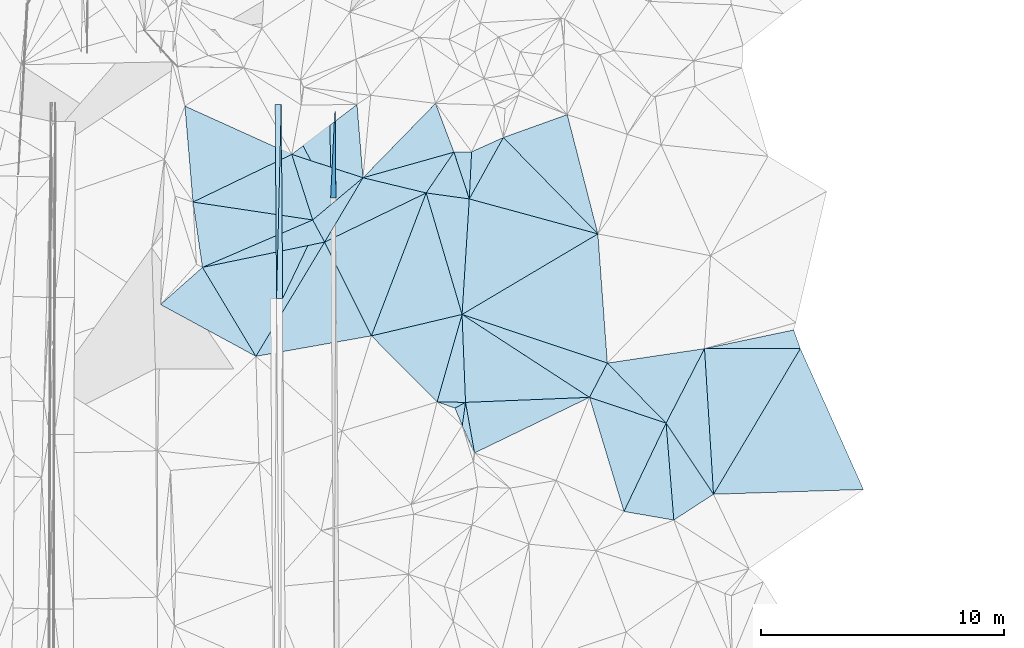
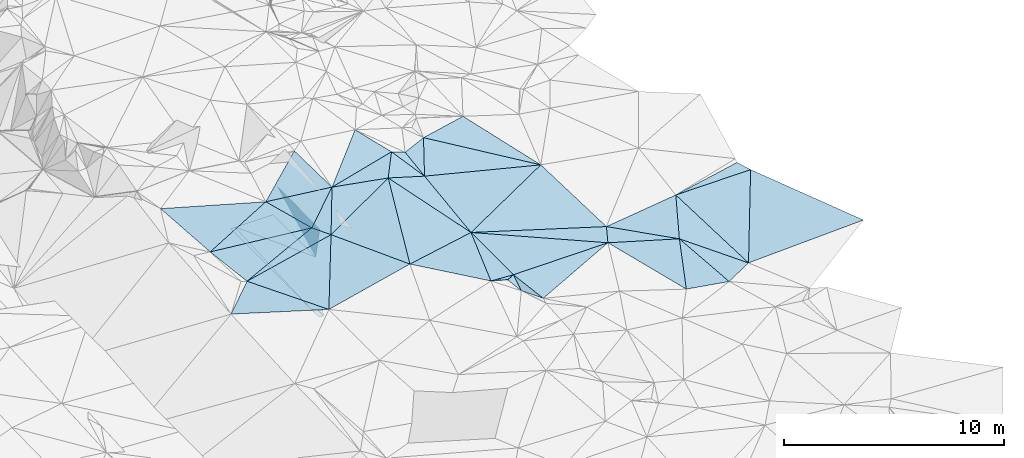
# One storey, part 154 of 275: 45 plates.
"""IFC2X3 building model written with IfcOpenShell, lengths in millimetres."""

from ifc_helpers import new_model, si_unit, frame, origin_with_axes, place, context, subcontext, project, spatial, polyline, outline, extrude, material, type_object, element, save


model = new_model("IFC2X3")

# Units and contexts
model_context = context("Model", 3, precision=1e-05, world=origin_with_axes())
body_context = subcontext(model_context, "Body", "Model", "MODEL_VIEW")
ifc_project = project(units=[si_unit("LENGTHUNIT", "METRE", prefix="MILLI"), si_unit("AREAUNIT", "SQUARE_METRE"), si_unit("VOLUMEUNIT", "CUBIC_METRE"), si_unit("MASSUNIT", "GRAM", prefix="KILO"), si_unit("TIMEUNIT", "SECOND"), si_unit("PLANEANGLEUNIT", "RADIAN"), si_unit("SOLIDANGLEUNIT", "STERADIAN"), si_unit("THERMODYNAMICTEMPERATUREUNIT", "DEGREE_CELSIUS"), si_unit("LUMINOUSINTENSITYUNIT", "LUMEN")], contexts=[model_context])

# Site, building, storey
site_placement = place(None, origin_with_axes())
site = spatial("IfcSite", under=ifc_project, at=site_placement, CompositionType="ELEMENT")
building_placement = place(site_placement, origin_with_axes())
building = spatial("IfcBuilding", under=site, at=building_placement, Name="Undefined", CompositionType="ELEMENT")
storey_placement = place(building_placement, origin_with_axes())
storey = spatial("IfcBuildingStorey", under=building, at=storey_placement, Name="Undefined", CompositionType="ELEMENT", Elevation=0.0)

# Plates
ifc_material = material()
plate_type_1 = type_object("IfcPlateType", PredefinedType="NOTDEFINED")
plate_1_placement = place(storey_placement, frame((-45854.497626776, 116819.736850131, 45079.1672889497), z_axis=(0.989904777680498, 0.00940713676587161, -0.141421486709737), x_axis=(0.00717878399998597, -0.999842046384469, -0.0162587620069682)))
element("IfcPlate", 1, at=plate_1_placement, inside=storey, type_object=plate_type_1, material=ifc_material, Name="00_PR", context=body_context, shape_type="SweptSolid", body=[
    extrude(outline(polyline([(0.0, 0.0), (3854.10668945313, 2.62953108176589e-08), (3878.49462890625, 1515.03259277344), (0.0, 0.0)])), frame((-8.85201319254618e-08, 2.18876761149539e-07, -0.5000001331573), z_axis=(0.0, 0.0, 1.0), x_axis=(1.0, 0.0, 0.0)), (0.0, 0.0, 1.0), 1.0),
])
plate_type_2 = type_object("IfcPlateType", PredefinedType="NOTDEFINED")
plate_2_placement = place(storey_placement, frame((-48262.0820711047, 108841.21722967, 43462.2636889726), z_axis=(-0.0500458474949194, 0.0158195453211128, -0.998621627611954), x_axis=(-0.00717874201638974, 0.99984302228221, 0.0161986560133216)))
element("IfcPlate", 2, at=plate_2_placement, inside=storey, type_object=plate_type_2, material=ifc_material, Name="00_PR", context=body_context, shape_type="SweptSolid", body=[
    extrude(outline(polyline([(0.0, 0.0), (7962.08056640625, 2.82307155430317e-09), (7961.8779296875, 250.31266784668), (0.0, 0.0)])), frame((-8.85201319254618e-08, 2.18876761149539e-07, -0.5000001331573), z_axis=(0.0, 0.0, 1.0), x_axis=(1.0, 0.0, 0.0)), (0.0, 0.0, 1.0), 1.0),
])
plate_3_placement = place(storey_placement, frame((-48262.0820711047, 108841.21722967, 43462.2636889726), z_axis=(-0.0500458474949194, 0.0158195453211128, -0.998621627611954), x_axis=(0.0242079910010822, 0.999600007164145, 0.0146218620268544)))
element("IfcPlate", 3, at=plate_3_placement, inside=storey, type_object=plate_type_2, material=ifc_material, Name="00_PR", context=body_context, shape_type="SweptSolid", body=[
    extrude(outline(polyline([(0.0, 0.0), (7965.8115234375, -3.57758835889399e-08), (7.66266965866089, 250.194519042969), (0.0, 0.0)])), frame((-8.85201319254618e-08, 2.18876761149539e-07, -0.5000001331573), z_axis=(0.0, 0.0, 1.0), x_axis=(1.0, 0.0, 0.0)), (0.0, 0.0, 1.0), 1.0),
])
plate_type_3 = type_object("IfcPlateType", PredefinedType="NOTDEFINED")
plate_4_placement = place(storey_placement, frame((-48069.2208194386, 116803.842755858, 43578.7380675492), z_axis=(-0.000116733050345423, 0.0162583409646745, -0.999867817625146), x_axis=(0.999974225600075, 0.00717970302518681, 1.81898970750644e-11)))
element("IfcPlate", 4, at=plate_4_placement, inside=storey, type_object=plate_type_3, material=ifc_material, Name="00_PR", context=body_context, shape_type="SweptSolid", body=[
    extrude(outline(polyline([(0.0, 0.0), (1999.99963378906, -2.02271621674299e-09), (1999.99890136719, 3854.10693359375), (0.0, 0.0)])), frame((-8.85201319254618e-08, 2.18876761149539e-07, -0.5000001331573), z_axis=(0.0, 0.0, 1.0), x_axis=(1.0, 0.0, 0.0)), (0.0, 0.0, 1.0), 1.0),
])
plate_5_placement = place(storey_placement, frame((-48069.2208763004, 116803.842724192, 43578.7380670428), z_axis=(-0.000232139139761633, 0.0161974056547133, -0.999868786472243), x_axis=(0.466962682965878, -0.884159254878869, -0.0144313800224497)))
element("IfcPlate", 5, at=plate_5_placement, inside=storey, type_object=plate_type_3, material=ifc_material, Name="00_PR", context=body_context, shape_type="SweptSolid", body=[
    extrude(outline(polyline([(0.0, 0.0), (4342.134765625, 1.09575921669602e-08), (7067.19384765625, 3667.3564453125), (0.0, 0.0)])), frame((-8.85201319254618e-08, 2.18876761149539e-07, -0.5000001331573), z_axis=(0.0, 0.0, 1.0), x_axis=(1.0, 0.0, 0.0)), (0.0, 0.0, 1.0), 1.0),
])
plate_type_4 = type_object("IfcPlateType", PredefinedType="NOTDEFINED")
plate_6_placement = place(storey_placement, frame((-40977.530119661, 114848.333264597, 46469.5372864705), z_axis=(-0.371214180810586, 0.0758830055772437, -0.925441408966386), x_axis=(0.928486728332201, 0.0189535901104278, -0.370881593952695)))
element("IfcPlate", 6, at=plate_6_placement, inside=storey, type_object=plate_type_4, material=ifc_material, Name="00", context=body_context, shape_type="SweptSolid", body=[
    extrude(outline(polyline([(0.0, 0.0), (781.920715332031, 5.96628524363041e-10), (700.454650878906, 1938.44348144531), (0.0, 0.0)])), frame((-8.85201319254618e-08, 2.18876761149539e-07, -0.5000001331573), z_axis=(0.0, 0.0, 1.0), x_axis=(1.0, 0.0, 0.0)), (0.0, 0.0, 1.0), 1.0),
])
plate_type_5 = type_object("IfcPlateType", PredefinedType="NOTDEFINED")
plate_7_placement = place(storey_placement, frame((-32264.1512021452, 103721.254792077, 45329.500036999), z_axis=(-0.00158180835738645, 0.0106217551427176, -0.999942336437461), x_axis=(-0.699469807448296, 0.714609225289123, 0.00869733292011016)))
element("IfcPlate", 7, at=plate_7_placement, inside=storey, type_object=plate_type_5, material=ifc_material, Name="00", context=body_context, shape_type="SweptSolid", body=[
    extrude(outline(polyline([(0.0, 0.0), (3449.33325195313, -1.36933522298932e-08), (1082.78894042969, 3267.48657226563), (0.0, 0.0)])), frame((-8.85201319254618e-08, 2.18876761149539e-07, -0.5000001331573), z_axis=(0.0, 0.0, 1.0), x_axis=(1.0, 0.0, 0.0)), (0.0, 0.0, 1.0), 1.0),
])
plate_type_6 = type_object("IfcPlateType", PredefinedType="NOTDEFINED")
plate_8_placement = place(storey_placement, frame((-38947.5543686607, 115450.475362066, 46179.5033495862), z_axis=(-0.115324672248958, 0.0048416818110664, -0.993316051459912), x_axis=(0.935858379331584, 0.335732603232216, -0.10701734888223)))
element("IfcPlate", 8, at=plate_8_placement, inside=storey, type_object=plate_type_6, material=ifc_material, Name="00", context=body_context, shape_type="SweptSolid", body=[
    extrude(outline(polyline([(0.0, 0.0), (2803.28369140625, -4.23460733145475e-09), (2354.38159179688, 5041.466796875), (0.0, 0.0)])), frame((-8.85201319254618e-08, 2.18876761149539e-07, -0.5000001331573), z_axis=(0.0, 0.0, 1.0), x_axis=(1.0, 0.0, 0.0)), (0.0, 0.0, 1.0), 1.0),
])
plate_type_7 = type_object("IfcPlateType", PredefinedType="NOTDEFINED")
plate_9_placement = place(storey_placement, frame((-49111.4682202364, 106463.319340459, 45639.5041980592), z_axis=(0.0939582829318605, 0.0889974877093829, -0.991590282450325), x_axis=(-0.877945165822361, 0.477055876197108, -0.0403729710939973)))
element("IfcPlate", 9, at=plate_9_placement, inside=storey, type_object=plate_type_7, material=ifc_material, Name="00", context=body_context, shape_type="SweptSolid", body=[
    extrude(outline(polyline([(0.0, 0.0), (4458.42822265625, 3.73984221369028e-09), (3665.740234375, 2179.57543945313), (0.0, 0.0)])), frame((-8.85201319254618e-08, 2.18876761149539e-07, -0.5000001331573), z_axis=(0.0, 0.0, 1.0), x_axis=(1.0, 0.0, 0.0)), (0.0, 0.0, 1.0), 1.0),
])
plate_type_8 = type_object("IfcPlateType", PredefinedType="NOTDEFINED")
plate_10_placement = place(storey_placement, frame((-44366.1117875183, 107303.824024435, 45989.5025681953), z_axis=(0.093344417096768, 0.0388178788658633, -0.994876872822572), x_axis=(-0.446390027282593, 0.894811363366184, -0.00696904106724978)))
element("IfcPlate", 10, at=plate_10_placement, inside=storey, type_object=plate_type_8, material=ifc_material, Name="00", context=body_context, shape_type="SweptSolid", body=[
    extrude(outline(polyline([(0.0, 0.0), (4304.75341796875, 5.7953002396971e-09), (4246.18994140625, 4656.17529296875), (0.0, 0.0)])), frame((-8.85201319254618e-08, 2.18876761149539e-07, -0.5000001331573), z_axis=(0.0, 0.0, 1.0), x_axis=(1.0, 0.0, 0.0)), (0.0, 0.0, 1.0), 1.0),
])
plate_type_9 = type_object("IfcPlateType", PredefinedType="NOTDEFINED")
plate_11_placement = place(storey_placement, frame((-46287.6770173666, 111155.789925573, 45959.5084004475), z_axis=(0.16067327182061, 0.0864819626131264, -0.983211559057888), x_axis=(-0.47395360510789, 0.880549816992335, -7.29566256069334e-11)))
element("IfcPlate", 11, at=plate_11_placement, inside=storey, type_object=plate_type_9, material=ifc_material, Name="00", context=body_context, shape_type="SweptSolid", body=[
    extrude(outline(polyline([(0.0, 0.0), (1033.10217285156, -1.51339918375015e-09), (1580.2890625, 2685.3837890625), (0.0, 0.0)])), frame((-8.85201319254618e-08, 2.18876761149539e-07, -0.5000001331573), z_axis=(0.0, 0.0, 1.0), x_axis=(1.0, 0.0, 0.0)), (0.0, 0.0, 1.0), 1.0),
])
plate_type_10 = type_object("IfcPlateType", PredefinedType="NOTDEFINED")
plate_12_placement = place(storey_placement, frame((-46287.7426761502, 111155.77189135, 45959.5008576438), z_axis=(0.0293554447012986, 0.0504131648804438, -0.998296935121573), x_axis=(-0.514728360151004, -0.855366699461899, -0.0583311641227519)))
element("IfcPlate", 12, at=plate_12_placement, inside=storey, type_object=plate_type_10, material=ifc_material, Name="00", context=body_context, shape_type="SweptSolid", body=[
    extrude(outline(polyline([(0.0, 0.0), (5485.91845703125, 1.3169483281672e-08), (3482.880859375, 3765.1083984375), (0.0, 0.0)])), frame((-8.85201319254618e-08, 2.18876761149539e-07, -0.5000001331573), z_axis=(0.0, 0.0, 1.0), x_axis=(1.0, 0.0, 0.0)), (0.0, 0.0, 1.0), 1.0),
])
plate_type_11 = type_object("IfcPlateType", PredefinedType="NOTDEFINED")
plate_13_placement = place(storey_placement, frame((-44711.8090655847, 113798.731764488, 46449.5070180951), z_axis=(0.0318343933986842, 0.163819712234825, -0.985976507468731), x_axis=(0.972198645509624, -0.234037620017432, -0.00749573784423279)))
element("IfcPlate", 13, at=plate_13_placement, inside=storey, type_object=plate_type_11, material=ifc_material, Name="00", context=body_context, shape_type="SweptSolid", body=[
    extrude(outline(polyline([(0.0, 0.0), (2668.18286132813, 8.41100700199604e-09), (-909.907653808594, 2980.044921875), (0.0, 0.0)])), frame((-8.85201319254618e-08, 2.18876761149539e-07, -0.5000001331573), z_axis=(0.0, 0.0, 1.0), x_axis=(1.0, 0.0, 0.0)), (0.0, 0.0, 1.0), 1.0),
])
plate_type_12 = type_object("IfcPlateType", PredefinedType="NOTDEFINED")
plate_14_placement = place(storey_placement, frame((-46777.3896260643, 112065.472098849, 45959.5008684253), z_axis=(0.0204070382615624, 0.0550534966426082, -0.998274844567774), x_axis=(-0.91790582451649, -0.394722701906474, -0.0405325291384133)))
element("IfcPlate", 14, at=plate_14_placement, inside=storey, type_object=plate_type_12, material=ifc_material, Name="00", context=body_context, shape_type="SweptSolid", body=[
    extrude(outline(polyline([(0.0, 0.0), (4934.30859375, 6.49015419185162e-09), (4225.71875, 2619.63745117188), (0.0, 0.0)])), frame((-8.85201319254618e-08, 2.18876761149539e-07, -0.5000001331573), z_axis=(0.0, 0.0, 1.0), x_axis=(1.0, 0.0, 0.0)), (0.0, 0.0, 1.0), 1.0),
])
plate_type_13 = type_object("IfcPlateType", PredefinedType="NOTDEFINED")
plate_15_placement = place(storey_placement, frame((-42117.8220206176, 113174.20719374, 46429.5001638836), z_axis=(-0.00168179319785188, 0.025031622937167, -0.999685245177086), x_axis=(-0.972198645510732, 0.234037620012776, 0.00749573784589082)))
element("IfcPlate", 15, at=plate_15_placement, inside=storey, type_object=plate_type_13, material=ifc_material, Name="00", context=body_context, shape_type="SweptSolid", body=[
    extrude(outline(polyline([(0.0, 0.0), (2668.18286132813, 8.41100700199604e-09), (-716.667541503906, 1895.0693359375), (0.0, 0.0)])), frame((-8.85201319254618e-08, 2.18876761149539e-07, -0.5000001331573), z_axis=(0.0, 0.0, 1.0), x_axis=(1.0, 0.0, 0.0)), (0.0, 0.0, 1.0), 1.0),
])
plate_type_14 = type_object("IfcPlateType", PredefinedType="NOTDEFINED")
plate_16_placement = place(storey_placement, frame((-42117.8426319736, 113174.240180338, 46429.5025437294), z_axis=(-0.0429041056604819, 0.0910042215964258, -0.994925861242486), x_axis=(0.281805296978904, -0.954304603494618, -0.099440928915674)))
element("IfcPlate", 16, at=plate_16_placement, inside=storey, type_object=plate_type_14, material=ifc_material, Name="00", context=body_context, shape_type="SweptSolid", body=[
    extrude(outline(polyline([(0.0, 0.0), (5229.2353515625, 3.01897671306506e-08), (5012.30078125, 3819.28515625), (0.0, 0.0)])), frame((-8.85201319254618e-08, 2.18876761149539e-07, -0.5000001331573), z_axis=(0.0, 0.0, 1.0), x_axis=(1.0, 0.0, 0.0)), (0.0, 0.0, 1.0), 1.0),
])
plate_type_15 = type_object("IfcPlateType", PredefinedType="NOTDEFINED")
plate_17_placement = place(storey_placement, frame((-40347.6346345835, 112929.087897959, 46059.5104503541), z_axis=(-0.198635113623785, 0.0433693038098068, -0.979113474078832), x_axis=(-0.0623655958741627, -0.99755508380361, -0.0315339060192841)))
element("IfcPlate", 17, at=plate_17_placement, inside=storey, type_object=plate_type_15, material=ifc_material, Name="00", context=body_context, shape_type="SweptSolid", body=[
    extrude(outline(polyline([(0.0, 0.0), (4756.78466796875, 7.63247953727841e-09), (-145.791763305664, 1819.24291992188), (0.0, 0.0)])), frame((-8.85201319254618e-08, 2.18876761149539e-07, -0.5000001331573), z_axis=(0.0, 0.0, 1.0), x_axis=(1.0, 0.0, 0.0)), (0.0, 0.0, 1.0), 1.0),
])
plate_type_16 = type_object("IfcPlateType", PredefinedType="NOTDEFINED")
plate_18_placement = place(storey_placement, frame((-35065.4977698381, 111492.149332647, 45709.5011168555), z_axis=(-0.0565723899980462, 0.0350779004838647, -0.997782093238575), x_axis=(-0.85972671872996, -0.509823495964205, 0.0308216168403517)))
element("IfcPlate", 18, at=plate_18_placement, inside=storey, type_object=plate_type_16, material=ifc_material, Name="00", context=body_context, shape_type="SweptSolid", body=[
    extrude(outline(polyline([(0.0, 0.0), (6488.9521484375, 1.02299964055419e-08), (3819.33764648438, 3937.02416992188), (0.0, 0.0)])), frame((-8.85201319254618e-08, 2.18876761149539e-07, -0.5000001331573), z_axis=(0.0, 0.0, 1.0), x_axis=(1.0, 0.0, 0.0)), (0.0, 0.0, 1.0), 1.0),
])
plate_type_17 = type_object("IfcPlateType", PredefinedType="NOTDEFINED")
plate_19_placement = place(storey_placement, frame((-44711.8395517022, 113798.71113614, 46449.5039899907), z_axis=(-0.0291359266201486, 0.12256348567626, -0.99203290759877), x_axis=(0.696481373727244, 0.714364409887418, 0.0678025511113927)))
element("IfcPlate", 19, at=plate_19_placement, inside=storey, type_object=plate_type_17, material=ifc_material, Name="00", context=body_context, shape_type="SweptSolid", body=[
    extrude(outline(polyline([(0.0, 0.0), (4277.125, -2.31957528740168e-08), (3352.18139648438, 1952.275390625), (0.0, 0.0)])), frame((-8.85201319254618e-08, 2.18876761149539e-07, -0.5000001331573), z_axis=(0.0, 0.0, 1.0), x_axis=(1.0, 0.0, 0.0)), (0.0, 0.0, 1.0), 1.0),
])
plate_type_18 = type_object("IfcPlateType", PredefinedType="NOTDEFINED")
plate_20_placement = place(storey_placement, frame((-38947.5197806288, 115450.509434511, 46179.5018767498), z_axis=(-0.0461451655607767, 0.0730371442540248, -0.996261109977994), x_axis=(0.697688568863958, -0.711403916706891, -0.084469687880667)))
element("IfcPlate", 20, at=plate_20_placement, inside=storey, type_object=plate_type_18, material=ifc_material, Name="00", context=body_context, shape_type="SweptSolid", body=[
    extrude(outline(polyline([(0.0, 0.0), (5564.1259765625, -2.66882125288248e-08), (827.084045410156, 2765.48950195313), (0.0, 0.0)])), frame((-8.85201319254618e-08, 2.18876761149539e-07, -0.5000001331573), z_axis=(0.0, 0.0, 1.0), x_axis=(1.0, 0.0, 0.0)), (0.0, 0.0, 1.0), 1.0),
])
plate_type_19 = type_object("IfcPlateType", PredefinedType="NOTDEFINED")
plate_21_placement = place(storey_placement, frame((-35065.5052511255, 111492.161986443, 45709.5022050042), z_axis=(-0.0715311244133379, 0.0604347157899568, -0.995605817262812), x_axis=(0.0728879751234871, -0.995177378240227, -0.0656454790622065)))
element("IfcPlate", 21, at=plate_21_placement, inside=storey, type_object=plate_type_19, material=ifc_material, Name="00", context=body_context, shape_type="SweptSolid", body=[
    extrude(outline(polyline([(0.0, 0.0), (5331.66943359375, 7.87986209616065e-09), (2872.51489257813, 5818.5185546875), (0.0, 0.0)])), frame((-8.85201319254618e-08, 2.18876761149539e-07, -0.5000001331573), z_axis=(0.0, 0.0, 1.0), x_axis=(1.0, 0.0, 0.0)), (0.0, 0.0, 1.0), 1.0),
])
plate_type_20 = type_object("IfcPlateType", PredefinedType="NOTDEFINED")
plate_22_placement = place(storey_placement, frame((-47639.1457419393, 114756.840470881, 46079.5082549315), z_axis=(0.154893738886192, 0.09345171245352, -0.983501249156991), x_axis=(0.943605486077026, -0.308844165939252, 0.119264277177311)))
element("IfcPlate", 22, at=plate_22_placement, inside=storey, type_object=plate_type_20, material=ifc_material, Name="00", context=body_context, shape_type="SweptSolid", body=[
    extrude(outline(polyline([(0.0, 0.0), (3102.35400390625, -9.63336788117886e-09), (1630.11706542969, 2311.54028320313), (0.0, 0.0)])), frame((-8.85201319254618e-08, 2.18876761149539e-07, -0.5000001331573), z_axis=(0.0, 0.0, 1.0), x_axis=(1.0, 0.0, 0.0)), (0.0, 0.0, 1.0), 1.0),
])
plate_type_21 = type_object("IfcPlateType", PredefinedType="NOTDEFINED")
plate_23_placement = place(storey_placement, frame((-40644.2121646322, 108183.938623848, 45909.5010373384), z_axis=(-0.0342772934961874, 0.0542476314691936, -0.997939006969143), x_axis=(-0.274310653958219, -0.960688175254333, -0.0428006431203394)))
element("IfcPlate", 23, at=plate_23_placement, inside=storey, type_object=plate_type_21, material=ifc_material, Name="00", context=body_context, shape_type="SweptSolid", body=[
    extrude(outline(polyline([(0.0, 0.0), (3738.26171875, 4.94765117764473e-10), (1863.05847167969, 3341.10961914063), (0.0, 0.0)])), frame((-8.85201319254618e-08, 2.18876761149539e-07, -0.5000001331573), z_axis=(0.0, 0.0, 1.0), x_axis=(1.0, 0.0, 0.0)), (0.0, 0.0, 1.0), 1.0),
])
plate_type_22 = type_object("IfcPlateType", PredefinedType="NOTDEFINED")
plate_24_placement = place(storey_placement, frame((-44958.6640059683, 116805.63260687, 46729.5090778947), z_axis=(0.158277829939945, 0.104425975197325, -0.981857089526571), x_axis=(0.0814906980706979, -0.992380920448498, -0.0924087379945298)))
element("IfcPlate", 24, at=plate_24_placement, inside=storey, type_object=plate_type_22, material=ifc_material, Name="00", context=body_context, shape_type="SweptSolid", body=[
    extrude(outline(polyline([(0.0, 0.0), (3030.0166015625, 4.47107595391572e-09), (1874.80822753906, 2879.25244140625), (0.0, 0.0)])), frame((-8.85201319254618e-08, 2.18876761149539e-07, -0.5000001331573), z_axis=(0.0, 0.0, 1.0), x_axis=(1.0, 0.0, 0.0)), (0.0, 0.0, 1.0), 1.0),
])
plate_type_23 = type_object("IfcPlateType", PredefinedType="NOTDEFINED")
plate_25_placement = place(storey_placement, frame((-26750.8894958001, 106781.874289018, 45389.5004626496), z_axis=(0.00760100272430908, 0.0418840368454916, -0.999093565295619), x_axis=(-0.999970882377901, -0.000358664098592917, -0.00762271319328473)))
element("IfcPlate", 25, at=plate_25_placement, inside=storey, type_object=plate_type_23, material=ifc_material, Name="00", context=body_context, shape_type="SweptSolid", body=[
    extrude(outline(polyline([(0.0, 0.0), (3935.60668945313, -4.23460733145475e-09), (272.130859375, 765.862121582031), (0.0, 0.0)])), frame((-8.85201319254618e-08, 2.18876761149539e-07, -0.5000001331573), z_axis=(0.0, 0.0, 1.0), x_axis=(1.0, 0.0, 0.0)), (0.0, 0.0, 1.0), 1.0),
])
plate_type_24 = type_object("IfcPlateType", PredefinedType="NOTDEFINED")
plate_26_placement = place(storey_placement, frame((-26750.8850394701, 106781.87430819, 45389.5005171163), z_axis=(0.016514240915898, 0.0419227098192385, -0.998984367369372), x_axis=(0.40846363204653, -0.912229871831938, -0.0315297039764449)))
element("IfcPlate", 26, at=plate_26_placement, inside=storey, type_object=plate_type_24, material=ifc_material, Name="00", context=body_context, shape_type="SweptSolid", body=[
    extrude(outline(polyline([(0.0, 0.0), (6343.224609375, 1.42645149026066e-08), (4010.86206054688, 5701.96337890625), (0.0, 0.0)])), frame((-8.85201319254618e-08, 2.18876761149539e-07, -0.5000001331573), z_axis=(0.0, 0.0, 1.0), x_axis=(1.0, 0.0, 0.0)), (0.0, 0.0, 1.0), 1.0),
])
plate_type_25 = type_object("IfcPlateType", PredefinedType="NOTDEFINED")
plate_27_placement = place(storey_placement, frame((-30316.3534751748, 100799.33848405, 45079.500580705), z_axis=(0.00759726746526176, 0.0472303367905564, -0.998855133046686), x_axis=(-0.0616806051147383, 0.997004047967301, 0.0466736680527114)))
element("IfcPlate", 27, at=plate_27_placement, inside=storey, type_object=plate_type_25, material=ifc_material, Name="00", context=body_context, shape_type="SweptSolid", body=[
    extrude(outline(polyline([(0.0, 0.0), (5999.10009765625, -4.14656824432313e-08), (5759.1640625, 3928.28588867188), (0.0, 0.0)])), frame((-8.85201319254618e-08, 2.18876761149539e-07, -0.5000001331573), z_axis=(0.0, 0.0, 1.0), x_axis=(1.0, 0.0, 0.0)), (0.0, 0.0, 1.0), 1.0),
])
plate_type_26 = type_object("IfcPlateType", PredefinedType="NOTDEFINED")
plate_28_placement = place(storey_placement, frame((-34676.9147359638, 106186.132250975, 45359.5054345674), z_axis=(-0.119696519694363, -0.0852160484878712, -0.989146585826979), x_axis=(-0.458471795858429, -0.878970507920316, 0.131203881835291)))
element("IfcPlate", 28, at=plate_28_placement, inside=storey, type_object=plate_type_26, material=ifc_material, Name="00", context=body_context, shape_type="SweptSolid", body=[
    extrude(outline(polyline([(0.0, 0.0), (1600.56237792969, 3.20142135024071e-10), (1052.06774902344, 6228.62353515625), (0.0, 0.0)])), frame((-8.85201319254618e-08, 2.18876761149539e-07, -0.5000001331573), z_axis=(0.0, 0.0, 1.0), x_axis=(1.0, 0.0, 0.0)), (0.0, 0.0, 1.0), 1.0),
])
plate_type_27 = type_object("IfcPlateType", PredefinedType="NOTDEFINED")
plate_29_placement = place(storey_placement, frame((-32264.2036730097, 103721.203375078, 45329.5049959999), z_axis=(-0.106524006582475, -0.092217888135618, -0.990024493196721), x_axis=(-0.945377603994932, 0.317901793872526, 0.0721084968462964)))
element("IfcPlate", 29, at=plate_29_placement, inside=storey, type_object=plate_type_27, material=ifc_material, Name="00", context=body_context, shape_type="SweptSolid", body=[
    extrude(outline(polyline([(0.0, 0.0), (3328.31787109375, 5.76255843043327e-09), (3066.68432617188, 1579.03381347656), (0.0, 0.0)])), frame((-8.85201319254618e-08, 2.18876761149539e-07, -0.5000001331573), z_axis=(0.0, 0.0, 1.0), x_axis=(1.0, 0.0, 0.0)), (0.0, 0.0, 1.0), 1.0),
])
plate_type_28 = type_object("IfcPlateType", PredefinedType="NOTDEFINED")
plate_30_placement = place(storey_placement, frame((-40644.2159129286, 108183.93968047, 45909.5012390847), z_axis=(-0.0417729249870167, 0.0563699316415018, -0.997535690361383), x_axis=(0.0392753381186003, -0.997542832984153, -0.0580150340654871)))
element("IfcPlate", 30, at=plate_30_placement, inside=storey, type_object=plate_type_28, material=ifc_material, Name="00", context=body_context, shape_type="SweptSolid", body=[
    extrude(outline(polyline([(0.0, 0.0), (3619.75146484375, 2.25481926463544e-08), (3551.48706054688, 1166.85046386719), (0.0, 0.0)])), frame((-8.85201319254618e-08, 2.18876761149539e-07, -0.5000001331573), z_axis=(0.0, 0.0, 1.0), x_axis=(1.0, 0.0, 0.0)), (0.0, 0.0, 1.0), 1.0),
])
plate_type_29 = type_object("IfcPlateType", PredefinedType="NOTDEFINED")
plate_31_placement = place(storey_placement, frame((-35410.7007875948, 104779.34215447, 45569.5013190639), z_axis=(-0.0663612607714766, 0.0288860872893397, -0.997377449629744), x_axis=(0.945377603995246, -0.317901793873339, -0.0721084968385878)))
element("IfcPlate", 31, at=plate_31_placement, inside=storey, type_object=plate_type_29, material=ifc_material, Name="00", context=body_context, shape_type="SweptSolid", body=[
    extrude(outline(polyline([(0.0, 0.0), (3328.31787109375, 5.76255843043327e-09), (2845.76171875, 3991.75903320313), (0.0, 0.0)])), frame((-8.85201319254618e-08, 2.18876761149539e-07, -0.5000001331573), z_axis=(0.0, 0.0, 1.0), x_axis=(1.0, 0.0, 0.0)), (0.0, 0.0, 1.0), 1.0),
])
plate_type_30 = type_object("IfcPlateType", PredefinedType="NOTDEFINED")
plate_32_placement = place(storey_placement, frame((-35410.6815016142, 104779.35618561, 45569.501012533), z_axis=(-0.0277893071785608, 0.0569469397693353, -0.997990380944347), x_axis=(-0.998855282994307, -0.040467991110821, 0.0255042218038197)))
element("IfcPlate", 32, at=plate_32_placement, inside=storey, type_object=plate_type_30, material=ifc_material, Name="00", context=body_context, shape_type="SweptSolid", body=[
    extrude(outline(polyline([(0.0, 0.0), (5097.1953125, -1.73604348674417e-08), (5098.43115234375, 3619.75122070313), (0.0, 0.0)])), frame((-8.85201319254618e-08, 2.18876761149539e-07, -0.5000001331573), z_axis=(0.0, 0.0, 1.0), x_axis=(1.0, 0.0, 0.0)), (0.0, 0.0, 1.0), 1.0),
])
plate_type_31 = type_object("IfcPlateType", PredefinedType="NOTDEFINED")
plate_33_placement = place(storey_placement, frame((-32264.2079318007, 103721.253633988, 45329.5033452434), z_axis=(-0.11504081075174, 0.00830128674218076, -0.993326079643541), x_axis=(0.553267721240836, -0.829971148137296, -0.0710121249691248)))
element("IfcPlate", 33, at=plate_33_placement, inside=storey, type_object=plate_type_31, material=ifc_material, Name="00", context=body_context, shape_type="SweptSolid", body=[
    extrude(outline(polyline([(0.0, 0.0), (3520.52563476563, 6.8939698394388e-09), (3485.18994140625, 1952.85717773438), (0.0, 0.0)])), frame((-8.85201319254618e-08, 2.18876761149539e-07, -0.5000001331573), z_axis=(0.0, 0.0, 1.0), x_axis=(1.0, 0.0, 0.0)), (0.0, 0.0, 1.0), 1.0),
])
plate_type_32 = type_object("IfcPlateType", PredefinedType="NOTDEFINED")
plate_34_placement = place(storey_placement, frame((-40502.0491542081, 104573.071991998, 45699.5007592867), z_axis=(-0.0421706355145646, 0.0350730295649387, -0.998494626974745), x_axis=(-0.878494964503368, -0.477318585868925, 0.0203362957864869)))
element("IfcPlate", 34, at=plate_34_placement, inside=storey, type_object=plate_type_32, material=ifc_material, Name="00", context=body_context, shape_type="SweptSolid", body=[
    extrude(outline(polyline([(0.0, 0.0), (491.731628417969, 2.09547579288483e-09), (1017.42486572266, 575.366516113281), (0.0, 0.0)])), frame((-8.85201319254618e-08, 2.18876761149539e-07, -0.5000001331573), z_axis=(0.0, 0.0, 1.0), x_axis=(1.0, 0.0, 0.0)), (0.0, 0.0, 1.0), 1.0),
])
plate_type_33 = type_object("IfcPlateType", PredefinedType="NOTDEFINED")
plate_35_placement = place(storey_placement, frame((-40637.0032913082, 103617.00195927, 45439.5281966927), z_axis=(-0.17463944896482, 0.281217101268194, -0.943619629310232), x_axis=(-0.35983214318617, 0.8738319589832, 0.327014581004625)))
element("IfcPlate", 35, at=plate_35_placement, inside=storey, type_object=plate_type_33, material=ifc_material, Name="00", context=body_context, shape_type="SweptSolid", body=[
    extrude(outline(polyline([(0.0, 0.0), (825.651245117188, 1.27602106658742e-09), (872.038879394531, 489.538757324219), (0.0, 0.0)])), frame((-8.85201319254618e-08, 2.18876761149539e-07, -0.5000001331573), z_axis=(0.0, 0.0, 1.0), x_axis=(1.0, 0.0, 0.0)), (0.0, 0.0, 1.0), 1.0),
])
plate_type_34 = type_object("IfcPlateType", PredefinedType="NOTDEFINED")
plate_36_placement = place(storey_placement, frame((-31947.0747694564, 99739.4542713832, 45259.5003952788), z_axis=(-0.0365240055009241, 0.0146577412424535, -0.999225273721516), x_axis=(-0.984785940821073, 0.169457328839498, 0.0384820018156035)))
element("IfcPlate", 36, at=plate_36_placement, inside=storey, type_object=plate_type_34, material=ifc_material, Name="00", context=body_context, shape_type="SweptSolid", body=[
    extrude(outline(polyline([(0.0, 0.0), (2078.89404296875, 2.5902409106493e-09), (989.708984375, 3870.48779296875), (0.0, 0.0)])), frame((-8.85201319254618e-08, 2.18876761149539e-07, -0.5000001331573), z_axis=(0.0, 0.0, 1.0), x_axis=(1.0, 0.0, 0.0)), (0.0, 0.0, 1.0), 1.0),
])
plate_type_35 = type_object("IfcPlateType", PredefinedType="NOTDEFINED")
plate_37_placement = place(storey_placement, frame((-40977.4358702884, 114848.369139626, 46469.514001492), z_axis=(-0.182705289848009, 0.147692177627719, -0.972011212758957), x_axis=(0.305567049225312, -0.931160071151385, -0.198921342045249)))
element("IfcPlate", 37, at=plate_37_placement, inside=storey, type_object=plate_type_35, material=ifc_material, Name="00", context=body_context, shape_type="SweptSolid", body=[
    extrude(outline(polyline([(0.0, 0.0), (2061.1162109375, -6.69933797325939e-09), (1218.32043457031, 1618.82531738281), (0.0, 0.0)])), frame((-8.85201319254618e-08, 2.18876761149539e-07, -0.5000001331573), z_axis=(0.0, 0.0, 1.0), x_axis=(1.0, 0.0, 0.0)), (0.0, 0.0, 1.0), 1.0),
])
plate_type_36 = type_object("IfcPlateType", PredefinedType="NOTDEFINED")
plate_38_placement = place(storey_placement, frame((-30316.3892168747, 100799.336229551, 45079.5014868232), z_axis=(-0.0638802405190839, 0.0427234625310273, -0.997042637313262), x_axis=(-0.553267721262715, 0.829971148123231, 0.071012124963056)))
element("IfcPlate", 38, at=plate_38_placement, inside=storey, type_object=plate_type_36, material=ifc_material, Name="00", context=body_context, shape_type="SweptSolid", body=[
    extrude(outline(polyline([(0.0, 0.0), (3520.52563476563, 6.8939698394388e-09), (5188.77099609375, 3010.95629882813), (0.0, 0.0)])), frame((-8.85201319254618e-08, 2.18876761149539e-07, -0.5000001331573), z_axis=(0.0, 0.0, 1.0), x_axis=(1.0, 0.0, 0.0)), (0.0, 0.0, 1.0), 1.0),
])
plate_type_37 = type_object("IfcPlateType", PredefinedType="NOTDEFINED")
plate_39_placement = place(storey_placement, frame((-49111.4806861764, 106463.288082044, 45639.5013680945), z_axis=(0.0688474162560451, 0.0265785220359931, -0.997273089700734), x_axis=(0.51472836012195, 0.855366699474705, 0.058331164191352)))
element("IfcPlate", 39, at=plate_39_placement, inside=storey, type_object=plate_type_37, material=ifc_material, Name="00", context=body_context, shape_type="SweptSolid", body=[
    extrude(outline(polyline([(0.0, 0.0), (5485.91845703125, 1.3169483281672e-08), (3181.94677734375, 3636.29125976563), (0.0, 0.0)])), frame((-8.85201319254618e-08, 2.18876761149539e-07, -0.5000001331573), z_axis=(0.0, 0.0, 1.0), x_axis=(1.0, 0.0, 0.0)), (0.0, 0.0, 1.0), 1.0),
])
plate_type_38 = type_object("IfcPlateType", PredefinedType="NOTDEFINED")
plate_40_placement = place(storey_placement, frame((-51306.6124033656, 110117.770621667, 45759.500417666), z_axis=(0.0358282408902325, 0.0192844554932187, -0.999171880574629), x_axis=(0.917905824496464, 0.394722701952129, 0.0405325291473119)))
element("IfcPlate", 40, at=plate_40_placement, inside=storey, type_object=plate_type_38, material=ifc_material, Name="00", context=body_context, shape_type="SweptSolid", body=[
    extrude(outline(polyline([(0.0, 0.0), (4934.30859375, 6.49015419185162e-09), (5024.67578125, 1029.14221191406), (0.0, 0.0)])), frame((-8.85201319254618e-08, 2.18876761149539e-07, -0.5000001331573), z_axis=(0.0, 0.0, 1.0), x_axis=(1.0, 0.0, 0.0)), (0.0, 0.0, 1.0), 1.0),
])
plate_type_39 = type_object("IfcPlateType", PredefinedType="NOTDEFINED")
plate_41_placement = place(storey_placement, frame((-40130.1800838528, 102496.019211359, 45519.573043936), z_axis=(0.494395606527608, 0.162448204339066, -0.853922458513191), x_axis=(-0.410897685166649, 0.909368409019901, -0.0649013790400775)))
element("IfcPlate", 41, at=plate_41_placement, inside=storey, type_object=plate_type_39, material=ifc_material, Name="00", context=body_context, shape_type="SweptSolid", body=[
    extrude(outline(polyline([(0.0, 0.0), (1232.63940429688, 6.83940015733242e-10), (2029.87170410156, 603.755432128906), (0.0, 0.0)])), frame((-8.85201319254618e-08, 2.18876761149539e-07, -0.5000001331573), z_axis=(0.0, 0.0, 1.0), x_axis=(1.0, 0.0, 0.0)), (0.0, 0.0, 1.0), 1.0),
])
plate_type_40 = type_object("IfcPlateType", PredefinedType="NOTDEFINED")
plate_42_placement = place(storey_placement, frame((-40130.4416473308, 102495.978583575, 45519.5018633368), z_axis=(-0.0287282136924947, 0.0811970285664126, -0.996283961674594), x_axis=(-0.175468938193793, 0.98080905910198, 0.0849955370159659)))
element("IfcPlate", 42, at=plate_42_placement, inside=storey, type_object=plate_type_40, material=ifc_material, Name="00", context=body_context, shape_type="SweptSolid", body=[
    extrude(outline(polyline([(0.0, 0.0), (2117.75830078125, -1.25437509268522e-08), (1415.64794921875, 5048.60791015625), (0.0, 0.0)])), frame((-8.85201319254618e-08, 2.18876761149539e-07, -0.5000001331573), z_axis=(0.0, 0.0, 1.0), x_axis=(1.0, 0.0, 0.0)), (0.0, 0.0, 1.0), 1.0),
])
plate_type_41 = type_object("IfcPlateType", PredefinedType="NOTDEFINED")
plate_43_placement = place(storey_placement, frame((-40347.5497149181, 112929.097911507, 46059.5012023037), z_axis=(-0.0285221238351208, 0.0633148102346492, -0.997585947804441), x_axis=(0.0495804853484006, 0.996853179473481, 0.0618507400621016)))
element("IfcPlate", 43, at=plate_43_placement, inside=storey, type_object=plate_type_41, material=ifc_material, Name="00", context=body_context, shape_type="SweptSolid", body=[
    extrude(outline(polyline([(0.0, 0.0), (1940.15466308594, -1.11904228106141e-08), (2590.30908203125, 1273.69519042969), (0.0, 0.0)])), frame((-8.85201319254618e-08, 2.18876761149539e-07, -0.5000001331573), z_axis=(0.0, 0.0, 1.0), x_axis=(1.0, 0.0, 0.0)), (0.0, 0.0, 1.0), 1.0),
])
plate_type_42 = type_object("IfcPlateType", PredefinedType="NOTDEFINED")
plate_44_placement = place(storey_placement, frame((-47639.2096164254, 114756.811412655, 46079.5004920656), z_axis=(0.0273358689136336, 0.0352483125451101, -0.999004658013895), x_axis=(-0.899909987348526, -0.434242260365985, -0.0399458881815836)))
element("IfcPlate", 44, at=plate_44_placement, inside=storey, type_object=plate_type_42, material=ifc_material, Name="00", context=body_context, shape_type="SweptSolid", body=[
    extrude(outline(polyline([(0.0, 0.0), (4506.095703125, -4.22005541622639e-10), (3088.14990234375, 3695.67724609375), (0.0, 0.0)])), frame((-8.85201319254618e-08, 2.18876761149539e-07, -0.5000001331573), z_axis=(0.0, 0.0, 1.0), x_axis=(1.0, 0.0, 0.0)), (0.0, 0.0, 1.0), 1.0),
])
plate_type_43 = type_object("IfcPlateType", PredefinedType="NOTDEFINED")
plate_45_placement = place(storey_placement, frame((-51694.2941091018, 112800.081975094, 45899.500738086), z_axis=(0.0197827342201476, 0.0508556931098228, -0.998510060993426), x_axis=(0.899909987335744, 0.434242260393691, 0.039945888168351)))
element("IfcPlate", 45, at=plate_45_placement, inside=storey, type_object=plate_type_43, material=ifc_material, Name="00", context=body_context, shape_type="SweptSolid", body=[
    extrude(outline(polyline([(0.0, 0.0), (4506.095703125, -4.22005541622639e-10), (4108.16845703125, 2800.38452148438), (0.0, 0.0)])), frame((-8.85201319254618e-08, 2.18876761149539e-07, -0.5000001331573), z_axis=(0.0, 0.0, 1.0), x_axis=(1.0, 0.0, 0.0)), (0.0, 0.0, 1.0), 1.0),
])

save(model, "model.ifc")
